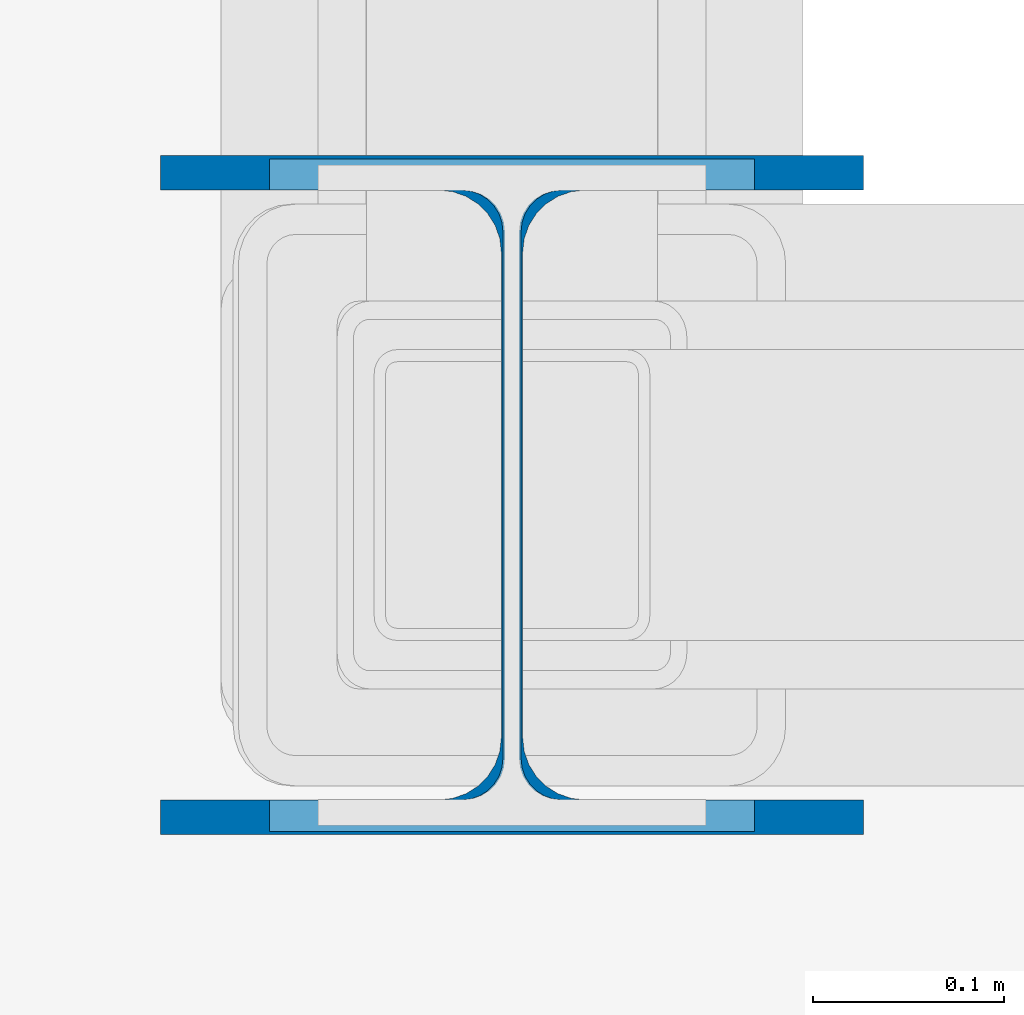
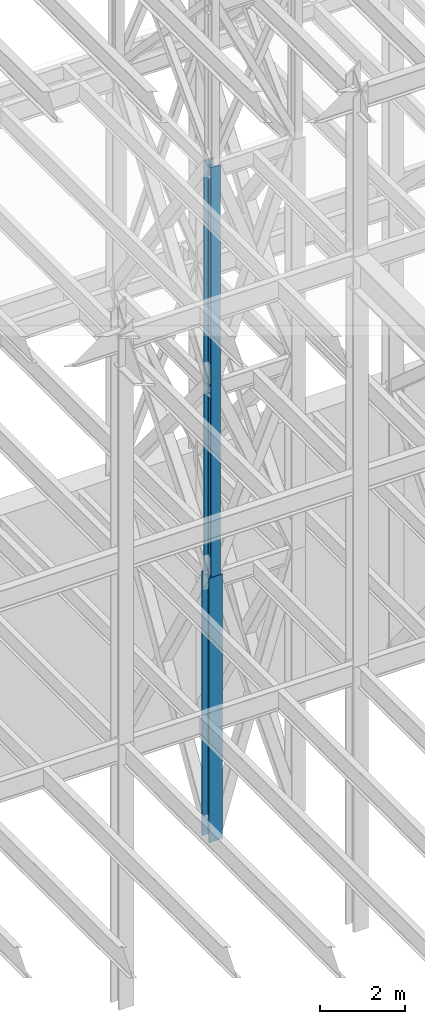
# One storey, part 103 of 150: 2 columns.
"""IFC2X3 building model written with IfcOpenShell, lengths in millimetres."""

from ifc_helpers import new_model, si_unit, frame, origin_with_axes, origin_2d_with_axis, place, context, subcontext, project, spatial, i_section, extrude, material, type_object, element, save


model = new_model("IFC2X3")

# Units and contexts
model_context = context("Model", 3, precision=1e-05, world=origin_with_axes())
body_context = subcontext(model_context, "Body", "Model", "MODEL_VIEW")
ifc_project = project(units=[si_unit("LENGTHUNIT", "METRE", prefix="MILLI"), si_unit("AREAUNIT", "SQUARE_METRE"), si_unit("VOLUMEUNIT", "CUBIC_METRE"), si_unit("MASSUNIT", "GRAM", prefix="KILO"), si_unit("TIMEUNIT", "SECOND"), si_unit("PLANEANGLEUNIT", "RADIAN"), si_unit("SOLIDANGLEUNIT", "STERADIAN"), si_unit("THERMODYNAMICTEMPERATUREUNIT", "DEGREE_CELSIUS"), si_unit("LUMINOUSINTENSITYUNIT", "LUMEN")], contexts=[model_context])

# Site, building, storey
site_placement = place(None, origin_with_axes())
site = spatial("IfcSite", under=ifc_project, at=site_placement, CompositionType="ELEMENT")
building_placement = place(site_placement, origin_with_axes())
building = spatial("IfcBuilding", under=site, at=building_placement, Name="Undefined", CompositionType="ELEMENT")
storey_placement = place(building_placement, origin_with_axes())
storey = spatial("IfcBuildingStorey", under=building, at=storey_placement, Name="Undefined", CompositionType="ELEMENT", Elevation=0.0)

# Columns
ifc_material = material(Name="STEEL/A992")
column_type_1 = type_object("IfcColumnType", Name="W14X61", PredefinedType="NOTDEFINED")
column_1_placement = place(storey_placement, frame((74663.3, 27355.8, 23774.4), z_axis=(0.0, 0.0, 1.0), x_axis=(1.0, 0.0, 0.0)))
element("IfcColumn", 1, at=column_1_placement, inside=storey, type_object=column_type_1, material=ifc_material, Name="COLUMN", ObjectType="W14X61", context=body_context, shape_type="SweptSolid", body=[
    extrude(i_section(OverallWidth=254.0, OverallDepth=352.425, WebThickness=9.5249, FlangeThickness=16.383, FilletRadius=21.717, at=origin_2d_with_axis()), frame((0.0, 0.0, 11811.0), z_axis=(0.0, 0.0, -1.0), x_axis=(-1.0, 0.0, 0.0)), (0.0, 0.0, 1.0), 11811.0),
])
column_type_2 = type_object("IfcColumnType", Name="W14X90", PredefinedType="NOTDEFINED")
column_2_placement = place(storey_placement, frame((74663.3, 27355.8, 16154.4), z_axis=(0.0, 0.0, 1.0), x_axis=(1.0, 0.0, 0.0)))
element("IfcColumn", 2, at=column_2_placement, inside=storey, type_object=column_type_2, material=ifc_material, Name="COLUMN", ObjectType="W14X90", context=body_context, shape_type="SweptSolid", body=[
    extrude(i_section(OverallWidth=368.3, OverallDepth=355.6, WebThickness=11.1125, FlangeThickness=18.034, FilletRadius=32.7659, at=origin_2d_with_axis()), frame((0.0, 0.0, 7620.0), z_axis=(0.0, 0.0, -1.0), x_axis=(-1.0, 0.0, 0.0)), (0.0, 0.0, 1.0), 7620.0),
])

save(model, "model.ifc")
